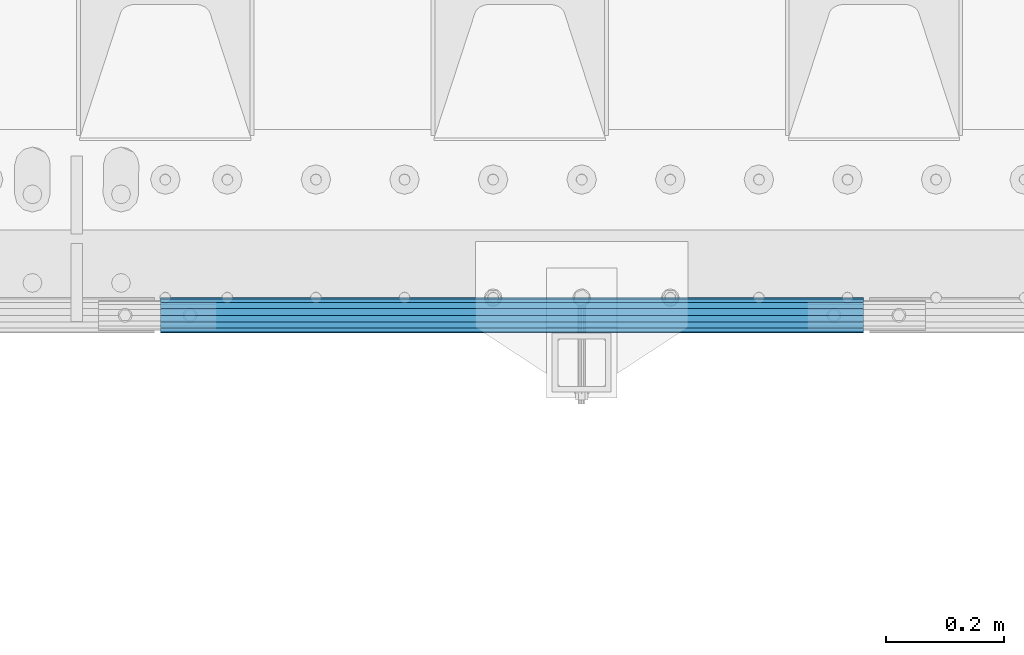
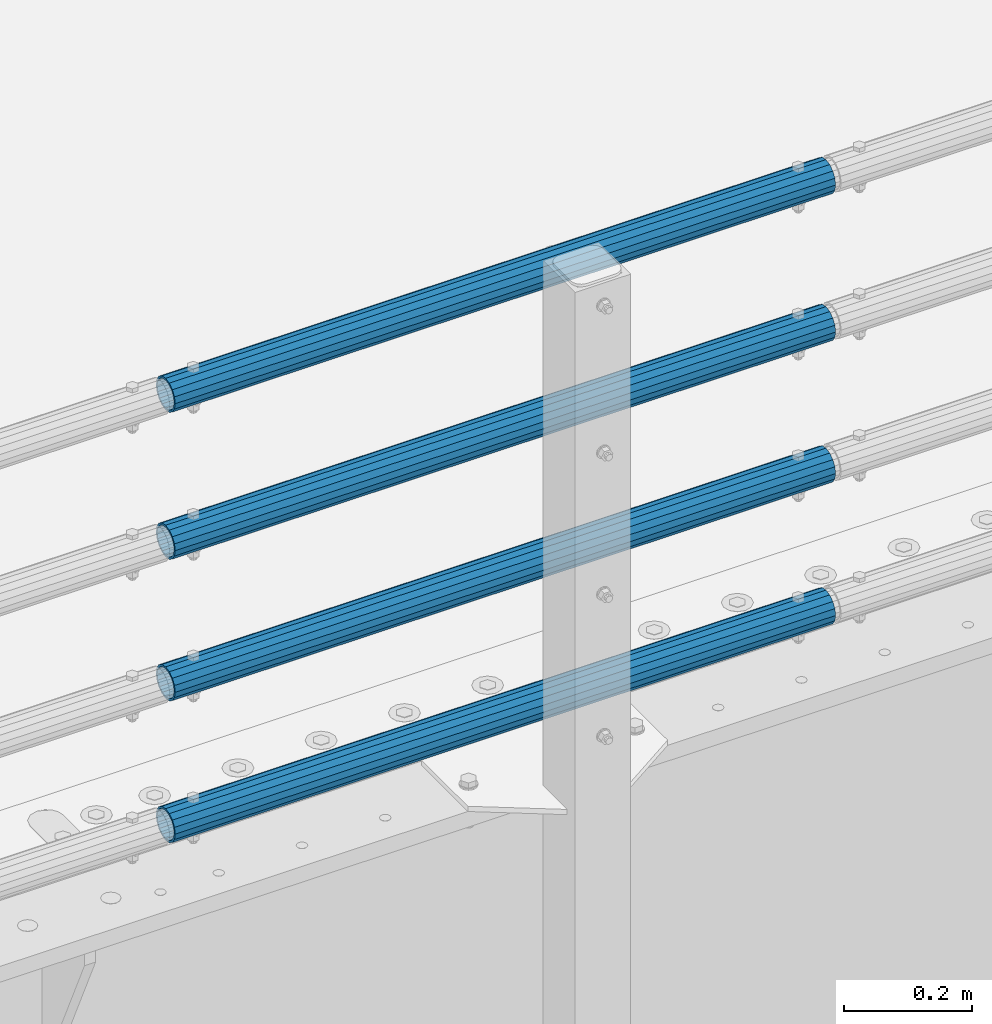
# One storey, part 103 of 219: 4 beams.
"""IFC2X3 building model written with IfcOpenShell, lengths in millimetres."""

from ifc_helpers import new_model, si_unit, frame, origin_with_axes, place, context, subcontext, project, spatial, faceted_brep, material, type_object, element, save


model = new_model("IFC2X3")

# Units and contexts
model_context = context("Model", 3, precision=1e-05, world=origin_with_axes())
body_context = subcontext(model_context, "Body", "Model", "MODEL_VIEW")
ifc_project = project(units=[si_unit("LENGTHUNIT", "METRE", prefix="MILLI"), si_unit("AREAUNIT", "SQUARE_METRE"), si_unit("VOLUMEUNIT", "CUBIC_METRE"), si_unit("MASSUNIT", "GRAM", prefix="KILO"), si_unit("TIMEUNIT", "SECOND"), si_unit("PLANEANGLEUNIT", "RADIAN"), si_unit("SOLIDANGLEUNIT", "STERADIAN"), si_unit("THERMODYNAMICTEMPERATUREUNIT", "DEGREE_CELSIUS"), si_unit("LUMINOUSINTENSITYUNIT", "LUMEN")], contexts=[model_context])

# Site, building, storey
site_placement = place(None, origin_with_axes())
site = spatial("IfcSite", under=ifc_project, at=site_placement, CompositionType="ELEMENT")
building_placement = place(site_placement, origin_with_axes())
building = spatial("IfcBuilding", under=site, at=building_placement, Name="Standard", CompositionType="ELEMENT")
storey_placement = place(building_placement, origin_with_axes())
storey = spatial("IfcBuildingStorey", under=building, at=storey_placement, Name="Undefined", CompositionType="ELEMENT", Elevation=0.0)

# Beams
ifc_material = material()
beam_type = type_object("IfcBeamType", PredefinedType="NOTDEFINED")
beam_1_placement = place(storey_placement, frame((11342.0000000001, 23870.1499999996, 419.849999999748), z_axis=(0.0, -1.0, 0.0), x_axis=(1.0, 0.0, 0.0)))
element("IfcBeam", 1, at=beam_1_placement, inside=storey, type_object=beam_type, material=ifc_material, context=body_context, shape_type="Brep", body=[
    faceted_brep([(0.0, -26.5500000000029, 0.0), (0.0, -24.5290015881765, 10.1602451292931), (1190.0, -24.5290015881747, 10.1602451292929), (1190.0, -26.55, 0.0), (0.0, -18.7736850405054, 18.7736850405028), (1190.0, -18.7736850405028, 18.7736850405054), (0.0, -10.1602451292929, 24.5290015881747), (1190.0, -10.1602451292931, 24.5290015881765), (0.0, 0.0, 26.55), (1190.0, 0.0, 26.5500000000029), (0.0, 10.1602451292929, 24.5290015881747), (1190.0, 10.1602451292932, 24.5290015881765), (0.0, 18.7736850405054, 18.7736850405028), (1190.0, 18.7736850405029, 18.7736850405054), (0.0, 24.5290015881765, 10.1602451292931), (1190.0, 24.5290015881747, 10.1602451292929), (0.0, 26.5500000000029, 0.0), (1190.0, 26.55, 0.0), (0.0, 24.5290015881765, -10.1602451292931), (1190.0, 24.5290015881747, -10.1602451292929), (0.0, 18.7736850405054, -18.7736850405028), (1190.0, 18.7736850405028, -18.7736850405054), (0.0, 10.1602451292929, -24.5290015881747), (1190.0, 10.1602451292931, -24.5290015881765), (0.0, 0.0, -26.55), (1190.0, 0.0, -26.5500000000029), (0.0, -10.1602451292929, -24.5290015881747), (1190.0, -10.1602451292931, -24.5290015881765), (0.0, -18.7736850405054, -18.7736850405028), (1190.0, -18.7736850405028, -18.7736850405054), (0.0, -24.5290015881765, -10.1602451292931), (1190.0, -24.5290015881747, -10.1602451292929), (0.0, -30.1500000000015, 0.0), (0.0, -27.8549679052157, -11.5379054858076), (1190.0, -27.8549679052153, -11.5379054858058), (1190.0, -30.15, 0.0), (0.0, -21.3192694527752, -21.3192694527752), (1190.0, -21.3192694527744, -21.3192694527752), (0.0, -11.5379054858058, -27.8549679052157), (1190.0, -11.5379054858075, -27.8549679052157), (0.0, 0.0, -30.1499999999996), (1190.0, 0.0, -30.1500000000015), (0.0, 11.5379054858058, -27.8549679052157), (1190.0, 11.5379054858075, -27.8549679052157), (0.0, 21.3192694527752, -21.3192694527752), (1190.0, 21.3192694527744, -21.3192694527752), (0.0, 27.8549679052157, -11.5379054858076), (1190.0, 27.8549679052153, -11.5379054858058), (0.0, 30.1500000000015, 0.0), (1190.0, 30.15, 0.0), (0.0, 27.8549679052157, 11.5379054858076), (1190.0, 27.8549679052153, 11.5379054858058), (0.0, 21.3192694527752, 21.3192694527752), (1190.0, 21.3192694527744, 21.3192694527752), (0.0, 11.5379054858058, 27.8549679052157), (1190.0, 11.5379054858075, 27.8549679052157), (0.0, 0.0, 30.1499999999996), (1190.0, 0.0, 30.1500000000015), (0.0, -11.5379054858058, 27.8549679052157), (1190.0, -11.5379054858075, 27.8549679052157), (0.0, -21.3192694527752, 21.3192694527752), (1190.0, -21.3192694527744, 21.3192694527752), (0.0, -27.8549679052157, 11.5379054858076), (1190.0, -27.8549679052153, 11.5379054858058)], [[[0, 1, 2, 3]], [[1, 4, 5, 2]], [[4, 6, 7, 5]], [[6, 8, 9, 7]], [[8, 10, 11, 9]], [[10, 12, 13, 11]], [[12, 14, 15, 13]], [[14, 16, 17, 15]], [[16, 18, 19, 17]], [[18, 20, 21, 19]], [[20, 22, 23, 21]], [[22, 24, 25, 23]], [[24, 26, 27, 25]], [[26, 28, 29, 27]], [[28, 30, 31, 29]], [[30, 0, 3, 31]], [[32, 33, 34, 35]], [[33, 36, 37, 34]], [[36, 38, 39, 37]], [[38, 40, 41, 39]], [[40, 42, 43, 41]], [[42, 44, 45, 43]], [[44, 46, 47, 45]], [[46, 48, 49, 47]], [[48, 50, 51, 49]], [[50, 52, 53, 51]], [[52, 54, 55, 53]], [[54, 56, 57, 55]], [[56, 58, 59, 57]], [[58, 60, 61, 59]], [[60, 62, 63, 61]], [[62, 32, 35, 63]], [[37, 39, 41, 43, 45, 47, 49, 51, 53, 55, 57, 59, 61, 63, 35, 34], [5, 7, 9, 11, 13, 15, 17, 19, 21, 23, 25, 27, 29, 31, 3, 2]], [[62, 60, 58, 56, 54, 52, 50, 48, 46, 44, 42, 40, 38, 36, 33, 32], [30, 28, 26, 24, 22, 20, 18, 16, 14, 12, 10, 8, 6, 4, 1, 0]]]),
])
beam_2_placement = place(storey_placement, frame((11342.0000000001, 23870.1499999996, 149.549999999748), z_axis=(0.0, -1.0, 0.0), x_axis=(1.0, 0.0, 0.0)))
element("IfcBeam", 2, at=beam_2_placement, inside=storey, type_object=beam_type, material=ifc_material, context=body_context, shape_type="Brep", body=[
    faceted_brep([(0.0, -26.5500000000029, 0.0), (0.0, -24.5290015881765, 10.1602451292931), (1190.0, -24.5290015881747, 10.1602451292929), (1190.0, -26.55, 0.0), (0.0, -18.7736850405054, 18.7736850405028), (1190.0, -18.7736850405028, 18.7736850405054), (0.0, -10.1602451292929, 24.5290015881747), (1190.0, -10.1602451292931, 24.5290015881765), (0.0, 0.0, 26.55), (1190.0, 0.0, 26.5500000000029), (0.0, 10.1602451292929, 24.5290015881747), (1190.0, 10.1602451292932, 24.5290015881765), (0.0, 18.7736850405054, 18.7736850405028), (1190.0, 18.7736850405029, 18.7736850405054), (0.0, 24.5290015881765, 10.1602451292931), (1190.0, 24.5290015881747, 10.1602451292929), (0.0, 26.5500000000029, 0.0), (1190.0, 26.55, 0.0), (0.0, 24.5290015881765, -10.1602451292931), (1190.0, 24.5290015881747, -10.1602451292929), (0.0, 18.7736850405054, -18.7736850405028), (1190.0, 18.7736850405028, -18.7736850405054), (0.0, 10.1602451292929, -24.5290015881747), (1190.0, 10.1602451292931, -24.5290015881765), (0.0, 0.0, -26.55), (1190.0, 0.0, -26.5500000000029), (0.0, -10.1602451292929, -24.5290015881747), (1190.0, -10.1602451292931, -24.5290015881765), (0.0, -18.7736850405054, -18.7736850405028), (1190.0, -18.7736850405028, -18.7736850405054), (0.0, -24.5290015881765, -10.1602451292931), (1190.0, -24.5290015881747, -10.1602451292929), (0.0, -30.1500000000015, 0.0), (0.0, -27.8549679052157, -11.5379054858076), (1190.0, -27.8549679052153, -11.5379054858058), (1190.0, -30.15, 0.0), (0.0, -21.3192694527752, -21.3192694527752), (1190.0, -21.3192694527744, -21.3192694527752), (0.0, -11.5379054858058, -27.8549679052157), (1190.0, -11.5379054858075, -27.8549679052157), (0.0, 0.0, -30.1499999999996), (1190.0, 0.0, -30.1500000000015), (0.0, 11.5379054858058, -27.8549679052157), (1190.0, 11.5379054858075, -27.8549679052157), (0.0, 21.3192694527752, -21.3192694527752), (1190.0, 21.3192694527744, -21.3192694527752), (0.0, 27.8549679052157, -11.5379054858076), (1190.0, 27.8549679052153, -11.5379054858058), (0.0, 30.1500000000015, 0.0), (1190.0, 30.15, 0.0), (0.0, 27.8549679052157, 11.5379054858076), (1190.0, 27.8549679052153, 11.5379054858058), (0.0, 21.3192694527752, 21.3192694527752), (1190.0, 21.3192694527744, 21.3192694527752), (0.0, 11.5379054858058, 27.8549679052157), (1190.0, 11.5379054858075, 27.8549679052157), (0.0, 0.0, 30.1499999999996), (1190.0, 0.0, 30.1500000000015), (0.0, -11.5379054858058, 27.8549679052157), (1190.0, -11.5379054858075, 27.8549679052157), (0.0, -21.3192694527752, 21.3192694527752), (1190.0, -21.3192694527744, 21.3192694527752), (0.0, -27.8549679052157, 11.5379054858076), (1190.0, -27.8549679052153, 11.5379054858058)], [[[0, 1, 2, 3]], [[1, 4, 5, 2]], [[4, 6, 7, 5]], [[6, 8, 9, 7]], [[8, 10, 11, 9]], [[10, 12, 13, 11]], [[12, 14, 15, 13]], [[14, 16, 17, 15]], [[16, 18, 19, 17]], [[18, 20, 21, 19]], [[20, 22, 23, 21]], [[22, 24, 25, 23]], [[24, 26, 27, 25]], [[26, 28, 29, 27]], [[28, 30, 31, 29]], [[30, 0, 3, 31]], [[32, 33, 34, 35]], [[33, 36, 37, 34]], [[36, 38, 39, 37]], [[38, 40, 41, 39]], [[40, 42, 43, 41]], [[42, 44, 45, 43]], [[44, 46, 47, 45]], [[46, 48, 49, 47]], [[48, 50, 51, 49]], [[50, 52, 53, 51]], [[52, 54, 55, 53]], [[54, 56, 57, 55]], [[56, 58, 59, 57]], [[58, 60, 61, 59]], [[60, 62, 63, 61]], [[62, 32, 35, 63]], [[37, 39, 41, 43, 45, 47, 49, 51, 53, 55, 57, 59, 61, 63, 35, 34], [5, 7, 9, 11, 13, 15, 17, 19, 21, 23, 25, 27, 29, 31, 3, 2]], [[62, 60, 58, 56, 54, 52, 50, 48, 46, 44, 42, 40, 38, 36, 33, 32], [30, 28, 26, 24, 22, 20, 18, 16, 14, 12, 10, 8, 6, 4, 1, 0]]]),
])
beam_3_placement = place(storey_placement, frame((11342.0000000001, 23870.1499999996, 969.549999999748), z_axis=(0.0, -1.0, 0.0), x_axis=(1.0, 0.0, 0.0)))
element("IfcBeam", 3, at=beam_3_placement, inside=storey, type_object=beam_type, material=ifc_material, context=body_context, shape_type="Brep", body=[
    faceted_brep([(0.0, -26.5500000000029, 0.0), (0.0, -24.5290015881765, 10.1602451292931), (1190.0, -24.5290015881747, 10.1602451292929), (1190.0, -26.55, 0.0), (0.0, -18.7736850405054, 18.7736850405028), (1190.0, -18.7736850405028, 18.7736850405054), (0.0, -10.1602451292929, 24.5290015881747), (1190.0, -10.1602451292931, 24.5290015881765), (0.0, 0.0, 26.55), (1190.0, 0.0, 26.5500000000029), (0.0, 10.1602451292929, 24.5290015881747), (1190.0, 10.1602451292932, 24.5290015881765), (0.0, 18.7736850405054, 18.7736850405028), (1190.0, 18.7736850405029, 18.7736850405054), (0.0, 24.5290015881765, 10.1602451292931), (1190.0, 24.5290015881747, 10.1602451292929), (0.0, 26.5500000000029, 0.0), (1190.0, 26.55, 0.0), (0.0, 24.5290015881765, -10.1602451292931), (1190.0, 24.5290015881747, -10.1602451292929), (0.0, 18.7736850405054, -18.7736850405028), (1190.0, 18.7736850405028, -18.7736850405054), (0.0, 10.1602451292929, -24.5290015881747), (1190.0, 10.1602451292931, -24.5290015881765), (0.0, 0.0, -26.55), (1190.0, 0.0, -26.5500000000029), (0.0, -10.1602451292929, -24.5290015881747), (1190.0, -10.1602451292931, -24.5290015881765), (0.0, -18.7736850405054, -18.7736850405028), (1190.0, -18.7736850405028, -18.7736850405054), (0.0, -24.5290015881765, -10.1602451292931), (1190.0, -24.5290015881747, -10.1602451292929), (0.0, -30.1500000000015, 0.0), (0.0, -27.8549679052157, -11.5379054858076), (1190.0, -27.8549679052153, -11.5379054858058), (1190.0, -30.15, 0.0), (0.0, -21.3192694527752, -21.3192694527752), (1190.0, -21.3192694527744, -21.3192694527752), (0.0, -11.5379054858058, -27.8549679052157), (1190.0, -11.5379054858075, -27.8549679052157), (0.0, 0.0, -30.1499999999996), (1190.0, 0.0, -30.1500000000015), (0.0, 11.5379054858058, -27.8549679052157), (1190.0, 11.5379054858075, -27.8549679052157), (0.0, 21.3192694527752, -21.3192694527752), (1190.0, 21.3192694527744, -21.3192694527752), (0.0, 27.8549679052157, -11.5379054858076), (1190.0, 27.8549679052153, -11.5379054858058), (0.0, 30.1500000000015, 0.0), (1190.0, 30.15, 0.0), (0.0, 27.8549679052157, 11.5379054858076), (1190.0, 27.8549679052153, 11.5379054858058), (0.0, 21.3192694527752, 21.3192694527752), (1190.0, 21.3192694527744, 21.3192694527752), (0.0, 11.5379054858058, 27.8549679052157), (1190.0, 11.5379054858075, 27.8549679052157), (0.0, 0.0, 30.1499999999996), (1190.0, 0.0, 30.1500000000015), (0.0, -11.5379054858058, 27.8549679052157), (1190.0, -11.5379054858075, 27.8549679052157), (0.0, -21.3192694527752, 21.3192694527752), (1190.0, -21.3192694527744, 21.3192694527752), (0.0, -27.8549679052157, 11.5379054858076), (1190.0, -27.8549679052153, 11.5379054858058)], [[[0, 1, 2, 3]], [[1, 4, 5, 2]], [[4, 6, 7, 5]], [[6, 8, 9, 7]], [[8, 10, 11, 9]], [[10, 12, 13, 11]], [[12, 14, 15, 13]], [[14, 16, 17, 15]], [[16, 18, 19, 17]], [[18, 20, 21, 19]], [[20, 22, 23, 21]], [[22, 24, 25, 23]], [[24, 26, 27, 25]], [[26, 28, 29, 27]], [[28, 30, 31, 29]], [[30, 0, 3, 31]], [[32, 33, 34, 35]], [[33, 36, 37, 34]], [[36, 38, 39, 37]], [[38, 40, 41, 39]], [[40, 42, 43, 41]], [[42, 44, 45, 43]], [[44, 46, 47, 45]], [[46, 48, 49, 47]], [[48, 50, 51, 49]], [[50, 52, 53, 51]], [[52, 54, 55, 53]], [[54, 56, 57, 55]], [[56, 58, 59, 57]], [[58, 60, 61, 59]], [[60, 62, 63, 61]], [[62, 32, 35, 63]], [[37, 39, 41, 43, 45, 47, 49, 51, 53, 55, 57, 59, 61, 63, 35, 34], [5, 7, 9, 11, 13, 15, 17, 19, 21, 23, 25, 27, 29, 31, 3, 2]], [[62, 60, 58, 56, 54, 52, 50, 48, 46, 44, 42, 40, 38, 36, 33, 32], [30, 28, 26, 24, 22, 20, 18, 16, 14, 12, 10, 8, 6, 4, 1, 0]]]),
])
beam_4_placement = place(storey_placement, frame((11342.0000000001, 23870.1499999996, 689.549999999748), z_axis=(0.0, -1.0, 0.0), x_axis=(1.0, 0.0, 0.0)))
element("IfcBeam", 4, at=beam_4_placement, inside=storey, type_object=beam_type, material=ifc_material, context=body_context, shape_type="Brep", body=[
    faceted_brep([(0.0, -26.5500000000029, 0.0), (0.0, -24.5290015881765, 10.1602451292931), (1190.0, -24.5290015881747, 10.1602451292929), (1190.0, -26.55, 0.0), (0.0, -18.7736850405054, 18.7736850405028), (1190.0, -18.7736850405028, 18.7736850405054), (0.0, -10.1602451292929, 24.5290015881747), (1190.0, -10.1602451292931, 24.5290015881765), (0.0, 0.0, 26.55), (1190.0, 0.0, 26.5500000000029), (0.0, 10.1602451292929, 24.5290015881747), (1190.0, 10.1602451292932, 24.5290015881765), (0.0, 18.7736850405054, 18.7736850405028), (1190.0, 18.7736850405029, 18.7736850405054), (0.0, 24.5290015881765, 10.1602451292931), (1190.0, 24.5290015881747, 10.1602451292929), (0.0, 26.5500000000029, 0.0), (1190.0, 26.55, 0.0), (0.0, 24.5290015881765, -10.1602451292931), (1190.0, 24.5290015881747, -10.1602451292929), (0.0, 18.7736850405054, -18.7736850405028), (1190.0, 18.7736850405028, -18.7736850405054), (0.0, 10.1602451292929, -24.5290015881747), (1190.0, 10.1602451292931, -24.5290015881765), (0.0, 0.0, -26.55), (1190.0, 0.0, -26.5500000000029), (0.0, -10.1602451292929, -24.5290015881747), (1190.0, -10.1602451292931, -24.5290015881765), (0.0, -18.7736850405054, -18.7736850405028), (1190.0, -18.7736850405028, -18.7736850405054), (0.0, -24.5290015881765, -10.1602451292931), (1190.0, -24.5290015881747, -10.1602451292929), (0.0, -30.1500000000015, 0.0), (0.0, -27.8549679052157, -11.5379054858076), (1190.0, -27.8549679052153, -11.5379054858058), (1190.0, -30.15, 0.0), (0.0, -21.3192694527752, -21.3192694527752), (1190.0, -21.3192694527744, -21.3192694527752), (0.0, -11.5379054858058, -27.8549679052157), (1190.0, -11.5379054858075, -27.8549679052157), (0.0, 0.0, -30.1499999999996), (1190.0, 0.0, -30.1500000000015), (0.0, 11.5379054858058, -27.8549679052157), (1190.0, 11.5379054858075, -27.8549679052157), (0.0, 21.3192694527752, -21.3192694527752), (1190.0, 21.3192694527744, -21.3192694527752), (0.0, 27.8549679052157, -11.5379054858076), (1190.0, 27.8549679052153, -11.5379054858058), (0.0, 30.1500000000015, 0.0), (1190.0, 30.15, 0.0), (0.0, 27.8549679052157, 11.5379054858076), (1190.0, 27.8549679052153, 11.5379054858058), (0.0, 21.3192694527752, 21.3192694527752), (1190.0, 21.3192694527744, 21.3192694527752), (0.0, 11.5379054858058, 27.8549679052157), (1190.0, 11.5379054858075, 27.8549679052157), (0.0, 0.0, 30.1499999999996), (1190.0, 0.0, 30.1500000000015), (0.0, -11.5379054858058, 27.8549679052157), (1190.0, -11.5379054858075, 27.8549679052157), (0.0, -21.3192694527752, 21.3192694527752), (1190.0, -21.3192694527744, 21.3192694527752), (0.0, -27.8549679052157, 11.5379054858076), (1190.0, -27.8549679052153, 11.5379054858058)], [[[0, 1, 2, 3]], [[1, 4, 5, 2]], [[4, 6, 7, 5]], [[6, 8, 9, 7]], [[8, 10, 11, 9]], [[10, 12, 13, 11]], [[12, 14, 15, 13]], [[14, 16, 17, 15]], [[16, 18, 19, 17]], [[18, 20, 21, 19]], [[20, 22, 23, 21]], [[22, 24, 25, 23]], [[24, 26, 27, 25]], [[26, 28, 29, 27]], [[28, 30, 31, 29]], [[30, 0, 3, 31]], [[32, 33, 34, 35]], [[33, 36, 37, 34]], [[36, 38, 39, 37]], [[38, 40, 41, 39]], [[40, 42, 43, 41]], [[42, 44, 45, 43]], [[44, 46, 47, 45]], [[46, 48, 49, 47]], [[48, 50, 51, 49]], [[50, 52, 53, 51]], [[52, 54, 55, 53]], [[54, 56, 57, 55]], [[56, 58, 59, 57]], [[58, 60, 61, 59]], [[60, 62, 63, 61]], [[62, 32, 35, 63]], [[37, 39, 41, 43, 45, 47, 49, 51, 53, 55, 57, 59, 61, 63, 35, 34], [5, 7, 9, 11, 13, 15, 17, 19, 21, 23, 25, 27, 29, 31, 3, 2]], [[62, 60, 58, 56, 54, 52, 50, 48, 46, 44, 42, 40, 38, 36, 33, 32], [30, 28, 26, 24, 22, 20, 18, 16, 14, 12, 10, 8, 6, 4, 1, 0]]]),
])

save(model, "model.ifc")
